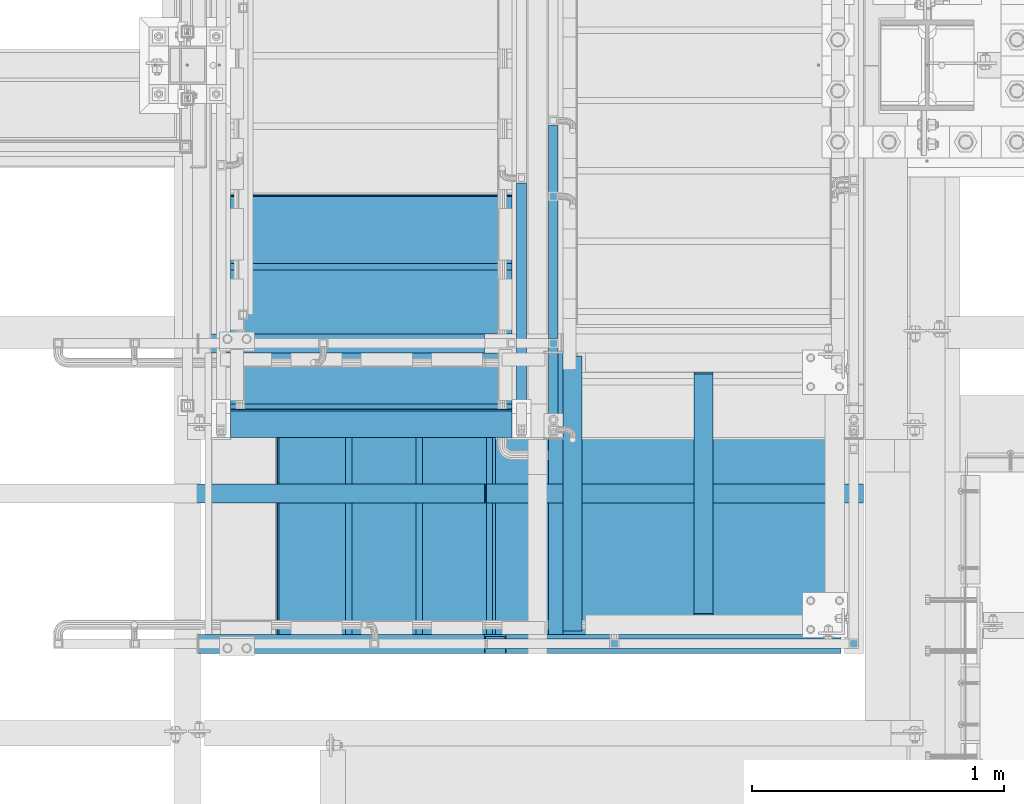
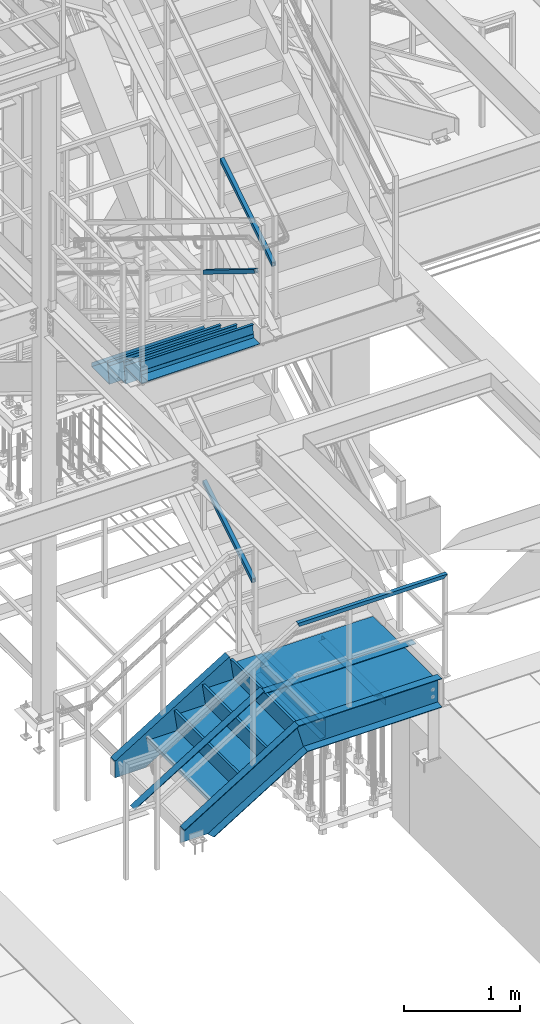
# One storey, part 1761 of 3843: 13 beams, 7 members, 8 elements without a shape of their own.
"""IFC2X3 building model written with IfcOpenShell, lengths in millimetres."""

from ifc_helpers import new_model, si_unit, frame, origin_with_axes, place, context, subcontext, project, spatial, faceted_brep, material, type_object, element, aggregate, save


model = new_model("IFC2X3")

# Units and contexts
model_context = context("Model", 3, precision=1e-05, world=origin_with_axes())
body_context = subcontext(model_context, "Body", "Model", "MODEL_VIEW")
ifc_project = project(units=[si_unit("LENGTHUNIT", "METRE", prefix="MILLI"), si_unit("AREAUNIT", "SQUARE_METRE"), si_unit("VOLUMEUNIT", "CUBIC_METRE"), si_unit("MASSUNIT", "GRAM", prefix="KILO"), si_unit("TIMEUNIT", "SECOND"), si_unit("PLANEANGLEUNIT", "RADIAN"), si_unit("SOLIDANGLEUNIT", "STERADIAN"), si_unit("THERMODYNAMICTEMPERATUREUNIT", "DEGREE_CELSIUS"), si_unit("LUMINOUSINTENSITYUNIT", "LUMEN")], contexts=[model_context])

# Site, building, storey
site_placement = place(None, origin_with_axes())
site = spatial("IfcSite", under=ifc_project, at=site_placement, CompositionType="ELEMENT")
building_placement = place(site_placement, origin_with_axes())
building = spatial("IfcBuilding", under=site, at=building_placement, Name="Undefined", CompositionType="ELEMENT")
storey_placement = place(building_placement, origin_with_axes())
storey = spatial("IfcBuildingStorey", under=building, at=storey_placement, Name="Undefined", CompositionType="ELEMENT", Elevation=0.0)

# Assembly, beam
assembly_1_placement = place(storey_placement, origin_with_axes())
assembly_1 = element("IfcElementAssembly", 1, at=assembly_1_placement, inside=storey, Name="RAIL", AssemblyPlace="NOTDEFINED", PredefinedType="RIGID_FRAME")
ifc_material_1 = material()
beam_type_1 = type_object("IfcBeamType", Name="HSS1-1/2X1-1/2X1/4", PredefinedType="NOTDEFINED")
beam_1_placement = place(assembly_1_placement, frame((54057.5499999943, 18008.6000001452, 32406.4923070972), z_axis=(0.0, 0.0, -1.0), x_axis=(1.0, 0.0, 0.0)))
beam_1 = element("IfcBeam", 2, at=beam_1_placement, type_object=beam_type_1, material=ifc_material_1, Name="RAIL", ObjectType="HSS1-1/2X1-1/2X1/4", context=body_context, shape_type="Brep", body=[
    faceted_brep([(1562.10000076667, -19.0499992350015, 19.0499992350015), (1562.10000076667, 19.0499992350015, 19.0499992350015), (126.041952911473, 19.0499992350015, 19.0499992350015), (126.041952911473, -19.0499992350015, 19.0499992350015), (1600.19999923668, -19.0499992350015, -19.0499992350015), (115.258045902359, -19.0499992350015, -19.0499992350015), (1600.19999923668, 19.0499992350015, -19.0499992350015), (115.258045902359, 19.0499992350015, -19.0499992350015), (1568.45000067168, -12.6999993300014, 12.6999993300014), (1568.45000067168, 12.6999993300014, 12.6999993300014), (1593.84999933167, 12.6999993300014, -12.6999993300014), (1593.84999933167, -12.6999993300014, -12.6999993300014), (124.24463503134, -12.6999993300014, 12.6999993300014), (124.24463503134, 12.6999993300014, 12.6999993300014), (117.0553637825, 12.6999993300014, -12.6999993300014), (117.0553637825, -12.6999993300014, -12.6999993300014)], [[[0, 1, 2, 3]], [[4, 0, 3, 5]], [[6, 4, 5, 7]], [[1, 6, 7, 2]], [[0, 4, 6, 1], [8, 9, 10, 11]], [[9, 8, 12, 13]], [[10, 9, 13, 14]], [[11, 10, 14, 15]], [[8, 11, 15, 12]], [[7, 5, 3, 2], [14, 13, 12, 15]]]),
])
aggregate(assembly_1, [beam_1])

# Assembly, member
assembly_2_placement = place(storey_placement, origin_with_axes())
assembly_2 = element("IfcElementAssembly", 3, at=assembly_2_placement, inside=storey, Name="RAIL", AssemblyPlace="NOTDEFINED", PredefinedType="RIGID_FRAME")
member_type_1 = type_object("IfcMemberType", Name="HSS1-1/2X1-1/2X1/4", PredefinedType="NOTDEFINED")
member_1_placement = place(assembly_2_placement, frame((54444.8999999993, 18859.5000000038, 35547.2230284888), z_axis=(0.0, -0.529536736899111, 0.848287005838379), x_axis=(0.0, 0.848287005838377, 0.529536736899114)))
member_1 = element("IfcMember", 4, at=member_1_placement, type_object=member_type_1, material=ifc_material_1, Name="RAIL", ObjectType="HSS1-1/2X1-1/2X1/4", context=body_context, shape_type="Brep", body=[
    faceted_brep([(1082.34320237271, -19.0499992350015, 19.0499992316145), (1058.55956696786, -19.0499992350015, -19.0499992382502), (1058.55956696786, 19.0499992350015, -19.0499992382502), (1082.34320237271, 19.0499992350015, 19.0499992316145), (1078.3792630387, -12.6999993299978, 12.6999993266436), (1078.3792630387, 12.6999993299978, 12.6999993266436), (1062.52350630188, 12.6999993299978, -12.6999993332684), (1062.52350630188, -12.6999993299978, -12.6999993332684), (34.3488397583606, 19.0499992350015, 19.0499992348923), (34.3488397583606, -19.0499999999956, 19.0499992348923), (10.5652043534537, -19.0499992350015, -19.0499992349432), (10.5652043534537, 19.0499992350015, -19.0499992349432), (30.3849004243275, -12.6999993300014, 12.6999993299178), (14.5291436874832, -12.6999993300014, -12.6999993299687), (14.5291436874832, 12.6999993300014, -12.6999993299687), (30.3849004243275, 12.6999993300014, 12.6999993299178)], [[[0, 1, 2, 3], [4, 5, 6, 7]], [[0, 3, 8, 9]], [[2, 1, 10, 11]], [[1, 0, 9, 10]], [[3, 2, 11, 8]], [[9, 8, 11, 10], [12, 13, 14, 15]], [[4, 7, 13, 12]], [[7, 6, 14, 13]], [[6, 5, 15, 14]], [[5, 4, 12, 15]]]),
])
aggregate(assembly_2, [member_1])

assembly_3_placement = place(storey_placement, origin_with_axes())
assembly_3 = element("IfcElementAssembly", 5, at=assembly_3_placement, inside=storey, Name="RAIL", AssemblyPlace="NOTDEFINED", PredefinedType="RIGID_FRAME")
member_2_placement = place(assembly_3_placement, frame((54317.8999999992, 19858.5666666609, 34931.5128165866), z_axis=(0.0, 0.5240974250506, 0.851658317082227), x_axis=(0.0, -0.851658317082228, 0.524097425050598)))
member_2 = element("IfcMember", 6, at=member_2_placement, type_object=member_type_1, material=ifc_material_1, Name="RAIL", ObjectType="HSS1-1/2X1-1/2X1/4", context=body_context, shape_type="Brep", body=[
    faceted_brep([(14.5527402998268, 12.6999993300014, -12.6999993299833), (14.5527402998268, -12.6999993300014, -12.6999993299833), (1050.19260690852, -12.6999993299978, -12.6999993321297), (1050.19260690852, 12.6999993299978, -12.6999993321297), (30.1835087105574, -12.6999993300014, 12.6999993299978), (1057.38187815647, -12.6999993299978, 12.699999327946), (30.1835087105574, 12.6999993300014, 12.6999993299978), (1057.38187815647, 12.6999993299978, 12.699999327946), (10.6450480494532, 19.0499992350015, -19.0499992349796), (34.091200960931, 19.0499992350015, 19.0499992349942), (1059.17919603638, 19.0499992350015, 19.0499992329715), (1048.39528902861, 19.0499992350015, -19.0499992371551), (34.091200960931, -19.0499992350015, 19.0499992349942), (1059.17919603638, -19.0499992350015, 19.0499992329715), (10.6450480494532, -19.0499992350015, -19.0499992349796), (1048.39528902861, -19.0499992350015, -19.0499992371551)], [[[0, 1, 2, 3]], [[1, 4, 5, 2]], [[4, 6, 7, 5]], [[6, 0, 3, 7]], [[8, 9, 10, 11]], [[9, 12, 13, 10]], [[12, 14, 15, 13]], [[14, 8, 11, 15]], [[13, 15, 11, 10], [5, 7, 3, 2]], [[14, 12, 9, 8], [6, 4, 1, 0]]]),
])
aggregate(assembly_3, [member_2])

assembly_4_placement = place(storey_placement, origin_with_axes())
assembly_4 = element("IfcElementAssembly", 7, at=assembly_4_placement, inside=storey, Name="RAIL", AssemblyPlace="NOTDEFINED", PredefinedType="RIGID_FRAME")
member_3_placement = place(assembly_4_placement, frame((54444.9000000015, 19202.3999999958, 32021.5846158689), z_axis=(0.0, -0.524097425050603, 0.851658317082225), x_axis=(0.0, 0.851658317082228, 0.524097425050598)))
member_3 = element("IfcMember", 8, at=member_3_placement, type_object=member_type_1, material=ifc_material_1, Name="RAIL", ObjectType="HSS1-1/2X1-1/2X1/4", context=body_context, shape_type="Brep", body=[
    faceted_brep([(1028.23010755839, -19.0499992350015, 19.0499992361583), (1004.7839546916, -19.0499992350015, -19.0499992338882), (1004.7839546916, 19.0499992350015, -19.0499992338882), (1028.23010755839, 19.0499992350015, 19.0499992361583), (1024.32241531547, -12.6999993299978, 12.6999993311474), (1024.32241531547, 12.6999993299978, 12.6999993311474), (1008.69164693452, 12.6999993299978, -12.6999993288846), (1008.69164693452, -12.6999993299978, -12.6999993288846), (34.091200960931, 19.0499992350015, 19.0499992349942), (34.091200960931, -19.0499992350015, 19.0499992349942), (10.6450480494532, -19.0499992350015, -19.0499992349796), (10.6450480494532, 19.0499992350015, -19.0499992349796), (30.1835087105574, 12.6999993300014, 12.6999993299978), (30.1835087105574, -12.6999993300014, 12.6999993299978), (14.5527402998268, -12.6999993300014, -12.6999993299833), (14.5527402998268, 12.6999993300014, -12.6999993299833)], [[[0, 1, 2, 3], [4, 5, 6, 7]], [[0, 3, 8, 9]], [[2, 1, 10, 11]], [[1, 0, 9, 10]], [[3, 2, 11, 8]], [[10, 9, 8, 11], [12, 13, 14, 15]], [[4, 7, 14, 13]], [[7, 6, 15, 14]], [[6, 5, 12, 15]], [[5, 4, 13, 12]]]),
])
aggregate(assembly_4, [member_3])

# Assembly, beams
assembly_5_placement = place(storey_placement, origin_with_axes())
assembly_5 = element("IfcElementAssembly", 9, at=assembly_5_placement, inside=storey, Name="STAIR", AssemblyPlace="NOTDEFINED", PredefinedType="RIGID_FRAME")
ifc_material_2 = material(Name="STEEL/ASTM A1011")
beam_type_2 = type_object("IfcBeamType", PredefinedType="NOTDEFINED")
beam_2_placement = place(assembly_5_placement, frame((53721.0000001991, 18935.6999999638, 34948.8124968837), z_axis=(-1.0, 0.0, 0.0), x_axis=(0.0, 1.0, 0.0)))
beam_2 = element("IfcBeam", 10, at=beam_2_placement, type_object=beam_type_2, material=ifc_material_2, Name="TREAD", context=body_context, shape_type="Brep", body=[
    faceted_brep([(0.0, -1.58750000000146, -558.799999999999), (0.0, -1.58750000000146, 558.799999999999), (0.0, 1.58750000000146, 558.799999999999), (0.0, 1.58750000000146, -558.799999999999), (21.7215083258779, 1.58750000000146, 558.799999999999), (21.7215083258779, 1.58750000000146, -558.799999999999), (25.3999999999942, -1.58750000000146, -558.799999999999), (25.3999999999942, -1.58750000000146, 558.799999999999), (-11.1830371286633, 224.325961538467, 558.799999999999), (-11.1830371286633, 224.325961538467, -558.799999999999), (-7.50454545454704, 221.150961538464, -558.799999999999), (-7.50454545454704, 221.150961538464, 558.799999999999), (293.616962871325, 224.325961538467, 558.799999999999), (293.616962871325, 224.325961538467, -558.799999999999), (290.876539379024, 221.150961538464, -558.799999999999), (290.876539379024, 221.150961538464, 558.799999999999), (299.585432747743, 183.924011605752, 558.799999999999), (299.585432747743, 183.924011605752, -558.799999999999), (296.444520385252, 183.460013188564, 558.799999999999), (296.444520385252, 183.460013188564, -558.799999999999)], [[[0, 1, 2, 3]], [[3, 2, 4, 5]], [[1, 0, 6, 7]], [[5, 4, 8, 9]], [[7, 6, 10, 11]], [[9, 8, 12, 13]], [[11, 10, 14, 15]], [[13, 12, 16, 17]], [[12, 8, 4, 2, 1, 7, 11, 15, 18, 16]], [[15, 14, 19, 18]], [[14, 10, 6, 0, 3, 5, 9, 13, 17, 19]], [[18, 19, 17, 16]]]),
])
beam_3_placement = place(assembly_5_placement, frame((53721.0000001966, 19215.0999999668, 34776.8740354687), z_axis=(-1.0, 0.0, 0.0), x_axis=(0.0, 1.0, 0.0)))
beam_3 = element("IfcBeam", 11, at=beam_3_placement, type_object=beam_type_2, material=ifc_material_2, Name="TREAD", context=body_context, shape_type="Brep", body=[
    faceted_brep([(0.0, -1.58750000000146, -558.799999999999), (0.0, -1.58750000000146, 558.799999999999), (0.0, 1.58750000000146, 558.799999999999), (0.0, 1.58750000000146, -558.799999999999), (21.7215083258779, 1.58750000000146, 558.799999999999), (21.7215083258779, 1.58750000000146, -558.799999999999), (25.3999999999942, -1.58750000000146, -558.799999999999), (25.3999999999942, -1.58750000000146, 558.799999999999), (-11.1830371286633, 224.325961538467, 558.799999999999), (-11.1830371286633, 224.325961538467, -558.799999999999), (-7.50454545454704, 221.150961538464, -558.799999999999), (-7.50454545454704, 221.150961538464, 558.799999999999), (293.616962871325, 224.325961538467, 558.799999999999), (293.616962871325, 224.325961538467, -558.799999999999), (290.876539379024, 221.150961538464, -558.799999999999), (290.876539379024, 221.150961538464, 558.799999999999), (299.585432747743, 183.924011605752, 558.799999999999), (299.585432747743, 183.924011605752, -558.799999999999), (296.444520385252, 183.460013188564, 558.799999999999), (296.444520385252, 183.460013188564, -558.799999999999)], [[[0, 1, 2, 3]], [[3, 2, 4, 5]], [[1, 0, 6, 7]], [[5, 4, 8, 9]], [[7, 6, 10, 11]], [[9, 8, 12, 13]], [[11, 10, 14, 15]], [[13, 12, 16, 17]], [[12, 8, 4, 2, 1, 7, 11, 15, 18, 16]], [[15, 14, 19, 18]], [[14, 10, 6, 0, 3, 5, 9, 13, 17, 19]], [[18, 19, 17, 16]]]),
])
beam_4_placement = place(assembly_5_placement, frame((53721.0000001941, 19494.4999999697, 34604.9355740537), z_axis=(-1.0, 0.0, 0.0), x_axis=(0.0, 1.0, 0.0)))
beam_4 = element("IfcBeam", 12, at=beam_4_placement, type_object=beam_type_2, material=ifc_material_2, Name="TREAD", context=body_context, shape_type="Brep", body=[
    faceted_brep([(0.0, -1.58750000000146, -558.799999999999), (0.0, -1.58750000000146, 558.799999999999), (0.0, 1.58750000000146, 558.799999999999), (0.0, 1.58750000000146, -558.799999999999), (21.7215083258779, 1.58750000000146, 558.799999999999), (21.7215083258779, 1.58750000000146, -558.799999999999), (25.3999999999942, -1.58750000000146, -558.799999999999), (25.3999999999942, -1.58750000000146, 558.799999999999), (-11.1830371286633, 224.325961538467, 558.799999999999), (-11.1830371286633, 224.325961538467, -558.799999999999), (-7.50454545454704, 221.150961538464, -558.799999999999), (-7.50454545454704, 221.150961538464, 558.799999999999), (293.616962871325, 224.325961538467, 558.799999999999), (293.616962871325, 224.325961538467, -558.799999999999), (290.876539379024, 221.150961538464, -558.799999999999), (290.876539379024, 221.150961538464, 558.799999999999), (299.585432747743, 183.924011605752, 558.799999999999), (299.585432747743, 183.924011605752, -558.799999999999), (296.444520385252, 183.460013188564, 558.799999999999), (296.444520385252, 183.460013188564, -558.799999999999)], [[[0, 1, 2, 3]], [[3, 2, 4, 5]], [[1, 0, 6, 7]], [[5, 4, 8, 9]], [[7, 6, 10, 11]], [[9, 8, 12, 13]], [[11, 10, 14, 15]], [[13, 12, 16, 17]], [[12, 8, 4, 2, 1, 7, 11, 15, 18, 16]], [[15, 14, 19, 18]], [[14, 10, 6, 0, 3, 5, 9, 13, 17, 19]], [[18, 19, 17, 16]]]),
])

# Assembly, beams, members
assembly_6_placement = place(storey_placement, origin_with_axes())
assembly_6 = element("IfcElementAssembly", 13, at=assembly_6_placement, inside=storey, Name="STAIR", AssemblyPlace="NOTDEFINED", PredefinedType="RIGID_FRAME")
beam_5_placement = place(assembly_6_placement, frame((54203.5999999953, 18605.5000001452, 31338.104807095), z_axis=(0.0, -1.0, 0.0), x_axis=(-1.0, 0.0, 0.0)))
beam_5 = element("IfcBeam", 14, at=beam_5_placement, type_object=beam_type_2, material=ifc_material_2, Name="TREAD", context=body_context, shape_type="Brep", body=[
    faceted_brep([(0.0, -1.58750000000146, -558.799999999999), (0.0, -1.58750000000146, 558.799999999999), (0.0, 1.58750000000146, 558.799999999999), (0.0, 1.58750000000146, -558.799999999999), (21.7215083258779, 1.58750000000146, 558.799999999999), (21.7215083258779, 1.58750000000146, -558.799999999999), (25.3999999999942, -1.58750000000146, -558.799999999999), (25.3999999999942, -1.58750000000146, 558.799999999999), (-11.1830371286633, 224.325961538467, 558.799999999999), (-11.1830371286633, 224.325961538467, -558.799999999999), (-7.50454545454704, 221.150961538464, -558.799999999999), (-7.50454545454704, 221.150961538464, 558.799999999999), (293.616962871325, 224.325961538467, 558.799999999999), (293.616962871325, 224.325961538467, -558.799999999999), (290.876539379024, 221.150961538464, -558.799999999999), (290.876539379024, 221.150961538464, 558.799999999999), (299.585432747743, 183.924011605752, 558.799999999999), (299.585432747743, 183.924011605752, -558.799999999999), (296.444520385252, 183.460013188564, 558.799999999999), (296.444520385252, 183.460013188564, -558.799999999999)], [[[0, 1, 2, 3]], [[3, 2, 4, 5]], [[1, 0, 6, 7]], [[5, 4, 8, 9]], [[7, 6, 10, 11]], [[9, 8, 12, 13]], [[11, 10, 14, 15]], [[13, 12, 16, 17]], [[12, 8, 4, 2, 1, 7, 11, 15, 18, 16]], [[15, 14, 19, 18]], [[14, 10, 6, 0, 3, 5, 9, 13, 17, 19]], [[18, 19, 17, 16]]]),
])
beam_6_placement = place(assembly_6_placement, frame((53924.199999994, 18605.5000001452, 31166.1663456759), z_axis=(0.0, -1.0, 0.0), x_axis=(-1.0, 0.0, 0.0)))
beam_6 = element("IfcBeam", 15, at=beam_6_placement, type_object=beam_type_2, material=ifc_material_2, Name="TREAD", context=body_context, shape_type="Brep", body=[
    faceted_brep([(0.0, -1.58750000000146, -558.799999999999), (0.0, -1.58750000000146, 558.799999999999), (0.0, 1.58750000000146, 558.799999999999), (0.0, 1.58750000000146, -558.799999999999), (21.7215083258779, 1.58750000000146, 558.799999999999), (21.7215083258779, 1.58750000000146, -558.799999999999), (25.3999999999942, -1.58750000000146, -558.799999999999), (25.3999999999942, -1.58750000000146, 558.799999999999), (-11.1830371286633, 224.325961538467, 558.799999999999), (-11.1830371286633, 224.325961538467, -558.799999999999), (-7.50454545454704, 221.150961538464, -558.799999999999), (-7.50454545454704, 221.150961538464, 558.799999999999), (293.616962871325, 224.325961538467, 558.799999999999), (293.616962871325, 224.325961538467, -558.799999999999), (290.876539379024, 221.150961538464, -558.799999999999), (290.876539379024, 221.150961538464, 558.799999999999), (299.585432747743, 183.924011605752, 558.799999999999), (299.585432747743, 183.924011605752, -558.799999999999), (296.444520385252, 183.460013188564, 558.799999999999), (296.444520385252, 183.460013188564, -558.799999999999)], [[[0, 1, 2, 3]], [[3, 2, 4, 5]], [[1, 0, 6, 7]], [[5, 4, 8, 9]], [[7, 6, 10, 11]], [[9, 8, 12, 13]], [[11, 10, 14, 15]], [[13, 12, 16, 17]], [[12, 8, 4, 2, 1, 7, 11, 15, 18, 16]], [[15, 14, 19, 18]], [[14, 10, 6, 0, 3, 5, 9, 13, 17, 19]], [[18, 19, 17, 16]]]),
])
beam_7_placement = place(assembly_6_placement, frame((53644.7999999928, 18605.5000001452, 30994.2278842569), z_axis=(0.0, -1.0, 0.0), x_axis=(-1.0, 0.0, 0.0)))
beam_7 = element("IfcBeam", 16, at=beam_7_placement, type_object=beam_type_2, material=ifc_material_2, Name="TREAD", context=body_context, shape_type="Brep", body=[
    faceted_brep([(0.0, -1.58750000000146, -558.799999999999), (0.0, -1.58750000000146, 558.799999999999), (0.0, 1.58750000000146, 558.799999999999), (0.0, 1.58750000000146, -558.799999999999), (21.7215083258779, 1.58750000000146, 558.799999999999), (21.7215083258779, 1.58750000000146, -558.799999999999), (25.3999999999942, -1.58750000000146, -558.799999999999), (25.3999999999942, -1.58750000000146, 558.799999999999), (-11.1830371286633, 224.325961538467, 558.799999999999), (-11.1830371286633, 224.325961538467, -558.799999999999), (-7.50454545454704, 221.150961538464, -558.799999999999), (-7.50454545454704, 221.150961538464, 558.799999999999), (293.616962871325, 224.325961538467, 558.799999999999), (293.616962871325, 224.325961538467, -558.799999999999), (290.876539379024, 221.150961538464, -558.799999999999), (290.876539379024, 221.150961538464, 558.799999999999), (299.585432747743, 183.924011605752, 558.799999999999), (299.585432747743, 183.924011605752, -558.799999999999), (296.444520385252, 183.460013188564, 558.799999999999), (296.444520385252, 183.460013188564, -558.799999999999)], [[[0, 1, 2, 3]], [[3, 2, 4, 5]], [[1, 0, 6, 7]], [[5, 4, 8, 9]], [[7, 6, 10, 11]], [[9, 8, 12, 13]], [[11, 10, 14, 15]], [[13, 12, 16, 17]], [[12, 8, 4, 2, 1, 7, 11, 15, 18, 16]], [[15, 14, 19, 18]], [[14, 10, 6, 0, 3, 5, 9, 13, 17, 19]], [[18, 19, 17, 16]]]),
])
ifc_material_3 = material(Name="STEEL/A36")
beam_type_3 = type_object("IfcBeamType", Name="C12X20.7", PredefinedType="NOTDEFINED")
beam_8_placement = place(assembly_6_placement, frame((54171.0107283524, 18008.600000064, 31212.6923070751), z_axis=(0.0, 0.0, 1.0), x_axis=(1.0, 0.0, 0.0)))
beam_8 = element("IfcBeam", 17, at=beam_8_placement, type_object=beam_type_3, material=ifc_material_3, Name="STAIR", ObjectType="C12X20.7", context=body_context, shape_type="Brep", body=[
    faceted_brep([(86.2712597135396, -38.0999999999985, -152.39999999988), (84.4732228755893, -38.0999999999985, -146.047459999883), (81.2543163632508, 30.1624999999985, -134.674927499889), (5.01694334564672, 30.1624999999985, 134.674927499867), (1.79803683332284, -38.0999999999985, 146.047459999862), (0.0, -38.0999999999985, 152.400000000001), (0.0, 38.0999999999985, 152.400000000001), (86.2712597135396, 38.0999999999985, -152.39999999988), (1416.88927164768, -38.0999999999985, 152.400000000001), (1416.88927164768, 38.0999999999985, 152.400000000001), (1416.88927164768, 38.0999999999985, -152.400000000001), (1416.88927164768, -38.0999999999985, -152.400000000001), (1416.88927164768, -38.0999999999985, -146.047460000002), (1416.88927164768, 30.1624999999985, -134.6749275), (1416.88927164768, 30.1624999999985, 134.6749275), (1416.88927164768, -38.0999999999985, 146.047460000002)], [[[0, 1, 2, 3, 4, 5, 6, 7]], [[6, 5, 8, 9]], [[7, 6, 9, 10]], [[0, 7, 10, 11]], [[1, 0, 11, 12]], [[2, 1, 12, 13]], [[3, 2, 13, 14]], [[4, 3, 14, 15]], [[5, 4, 15, 8]], [[14, 13, 12, 11, 10, 9, 8, 15]]]),
])
member_type_2 = type_object("IfcMemberType", Name="C12X20.7", PredefinedType="NOTDEFINED")
member_4_placement = place(assembly_6_placement, frame((54250.8831759882, 19202.4000000608, 31235.2995795919), z_axis=(-0.524097425775922, 0.0, 0.851658316635875), x_axis=(-0.851658316635875, 0.0, -0.524097425775922)))
member_4 = element("IfcMember", 18, at=member_4_placement, type_object=member_type_2, material=ifc_material_3, Name="STAIR", ObjectType="C12X20.7", context=body_context, shape_type="Brep", body=[
    faceted_brep([(86.2712597135396, -38.0999999999985, -152.39999999988), (84.4732228755893, -38.0999999999985, -146.047459999883), (81.2543163632508, 30.1624999999985, -134.674927499889), (5.01694334564672, 30.1624999999985, 134.674927499867), (1.79803683332284, -38.0999999999985, 146.047459999862), (0.0, -38.0999999999985, 152.400000000001), (0.0, 38.0999999999985, 152.400000000001), (86.2712597135396, 38.0999999999985, -152.39999999988), (1169.26132963897, 38.0999999999985, -152.399999998874), (1169.26132963897, -38.0999999999985, -152.399999998874), (1179.58420715575, -38.0999999999985, -146.047459998881), (1198.0645724983, 30.1624999999985, -134.67492749888), (1424.54121528564, 30.1624999999985, 4.69531398983236), (1344.55376094554, 30.1624999999985, 134.674927500895), (1337.5552794183, -38.0999999999985, 146.047460000875), (1333.64602403997, -38.0999999999985, 152.400000000864), (1333.64602403997, 38.0999999999985, 152.400000000864), (1424.54121528564, 38.0999999999985, 4.69531398983236)], [[[0, 1, 2, 3, 4, 5, 6, 7]], [[0, 7, 8, 9]], [[1, 0, 9, 10]], [[2, 1, 10, 11]], [[3, 2, 11, 12, 13]], [[4, 3, 13, 14]], [[5, 4, 14, 15]], [[6, 5, 15, 16]], [[8, 7, 6, 16, 17]], [[11, 10, 9, 8, 17, 12]], [[16, 15, 14, 13, 12, 17]]]),
])
member_5_placement = place(assembly_6_placement, frame((52936.4331760563, 18008.6000000644, 30426.4072725079), z_axis=(-0.524097425775922, 0.0, 0.851658316635875), x_axis=(0.851658316635872, 0.0, 0.524097425775926)))
member_5 = element("IfcMember", 19, at=member_5_placement, type_object=member_type_2, material=ifc_material_3, Name="STAIR", ObjectType="C12X20.7", context=body_context, shape_type="Brep", body=[
    faceted_brep([(345.336078011489, 30.1624999999985, -134.67492749968), (363.81644331853, -38.0999999999985, -146.047459999656), (1458.9274283898, -38.0999999999985, -146.047460000975), (1462.14633489506, 30.1624999999985, -134.674927500992), (374.139320815477, -38.0999999999985, -152.399999999641), (1457.12939155579, -38.0999999999985, -152.400000000967), (374.139320815477, 38.0999999999985, -152.399999999641), (1457.12939155579, 38.0999999999985, -152.400000000967), (1543.40065108441, -38.0999999999985, 152.399999998581), (1541.60261425041, -38.0999999999985, 146.047459998592), (1538.38370774514, 30.1624999999985, 134.674927498605), (1543.40065108441, 38.0999999999985, 152.399999998581), (209.754625973874, -38.0999999999985, 152.399999999951), (205.845370588111, -38.0999999999985, 146.047459999954), (198.846889047592, 30.1624999999985, 134.674927499964), (118.859434858809, 30.1624999999985, 4.69531448134148), (118.859434858809, 38.0999999999985, 4.69531448134148), (209.754625973874, 38.0999999999985, 152.399999999951)], [[[0, 1, 2, 3]], [[1, 4, 5, 2]], [[4, 6, 7, 5]], [[8, 9, 10, 3, 2, 5, 7, 11]], [[9, 8, 12, 13]], [[10, 9, 13, 14]], [[0, 3, 10, 14, 15]], [[6, 4, 1, 0, 15, 16]], [[11, 7, 6, 16, 17]], [[8, 11, 17, 12]], [[16, 15, 14, 13, 12, 17]]]),
])
beam_type_4 = type_object("IfcBeamType", Name="L3X3X1/4", PredefinedType="NOTDEFINED")
beam_9_placement = place(assembly_6_placement, frame((55041.7999999999, 19164.3000000617, 31250.7923071027), z_axis=(-1.0, 0.0, 0.0), x_axis=(0.0, -1.0, 0.0)))
beam_9 = element("IfcBeam", 20, at=beam_9_placement, type_object=beam_type_4, material=ifc_material_3, Name="ANGLE", ObjectType="L3X3X1/4", context=body_context, shape_type="Brep", body=[
    faceted_brep([(1041.40000012286, 31.75, 38.0999999999985), (1041.40000012286, 31.75, -31.75), (1041.40000012286, 31.7499999942156, -38.0999999999985), (1035.05000012226, 38.0999999999985, -38.0999999999985), (1035.05000012226, 38.0999999999985, 38.0999999999985), (1098.55000012286, 31.75, -31.75), (1098.55000012286, 31.7499999942156, -38.0999999999985), (1111.25000012285, 19.0499999942185, -31.75), (1111.25000012285, 19.0499999942185, -38.0999999999985), (1111.25000012344, -38.1000000057757, -31.75), (1111.25000012344, -38.0999999999985, -38.0999999999985), (82.5500000005923, 38.0999999999985, 38.0999999999985), (82.5499948264696, 38.0999999999458, -38.0999999999985), (76.1999999999971, 31.7499999999927, -38.0999999999985), (76.1999999999971, 31.75, -31.75), (76.1999999999971, 31.75, 38.0999999999985), (19.0499999999956, 31.7499999999927, -38.0999999999985), (19.0500000000029, 31.75, -31.75), (6.34999999999854, 19.0499999999956, -38.0999999999985), (6.34999999999854, 19.0499999999956, -31.75), (6.34999999941647, -38.0999999999985, -31.75), (6.34999999941647, -38.0999999999985, -38.0999999999985)], [[[0, 1, 2, 3, 4]], [[5, 6, 2, 1]], [[7, 8, 6, 5]], [[9, 10, 8, 7]], [[11, 12, 13, 14, 15]], [[14, 13, 16, 17]], [[17, 16, 18, 19]], [[20, 19, 18, 21]], [[5, 1, 14, 17, 19, 20, 9, 7]], [[15, 14, 1, 0]], [[11, 15, 0, 4]], [[12, 11, 4, 3]], [[21, 18, 16, 13, 12, 3, 2, 6, 8, 10]], [[20, 21, 10, 9]]]),
])
beam_10_placement = place(assembly_6_placement, frame((54521.0999999999, 18059.4000001457, 31250.792307111), z_axis=(1.0, 0.0, 0.0), x_axis=(0.0, 1.0, 0.0)))
beam_10 = element("IfcBeam", 21, at=beam_10_placement, type_object=beam_type_4, material=ifc_material_3, Name="ANGLE", ObjectType="L3X3X1/4", context=body_context, shape_type="Brep", body=[
    faceted_brep([(0.0, 25.3999999519947, -31.75), (0.0, 25.4000000000015, -38.0999999999985), (88.9000015258935, 25.399999952002, -38.0999999999985), (88.9000015258935, 25.399999952002, -31.75), (88.9000015261336, -38.1000000000131, -31.75), (88.9000015261336, -38.0999999999985, -38.0999999999985), (0.0, 38.0999999999985, -38.0999999999985), (0.0, 38.0999999999985, 38.0999999999985), (1092.20000022635, 38.0999999990308, 38.0999999999985), (1092.20000022635, 38.0999999990308, -38.0999999999985), (0.0, 31.75, 38.0999999999985), (1092.19999991878, 31.75, 38.0999999999985), (0.0, 31.75, -31.75), (1092.20000022113, 31.75, -31.75), (1092.19999991823, 25.3999999520238, -31.75), (1092.19999991849, 25.3999999520238, -38.0999999999985), (1003.29999839235, 25.3999999520238, -31.75), (1003.29999839235, 25.3999999520238, -38.0999999999985), (1003.29999998639, -38.0999999999985, -31.75), (1003.29999998639, -38.0999999999985, -38.0999999999985)], [[[0, 1, 2, 3]], [[4, 3, 2, 5]], [[6, 7, 8, 9]], [[7, 10, 11, 8]], [[10, 12, 13, 11]], [[9, 8, 11, 13, 14, 15]], [[14, 16, 17, 15]], [[18, 19, 17, 16]], [[19, 18, 4, 5]], [[1, 6, 9, 15, 17, 19, 5, 2]], [[12, 10, 7, 6, 1, 0]], [[18, 16, 14, 13, 12, 0, 3, 4]]]),
])

# Assembly, member
assembly_7_placement = place(storey_placement, origin_with_axes())
assembly_7 = element("IfcElementAssembly", 22, at=assembly_7_placement, inside=storey, Name="ref.", AssemblyPlace="NOTDEFINED", PredefinedType="RIGID_FRAME")
ifc_material_4 = material(Name="STEEL/Steel_Undefined")
member_type_3 = type_object("IfcMemberType", PredefinedType="NOTDEFINED")
member_6_placement = place(assembly_7_placement, frame((54178.1999999953, 18605.5000001452, 31336.5173070972), z_axis=(0.0, 1.0, 0.0), x_axis=(1.0, 0.0, 0.0)))
member_6 = element("IfcMember", 23, at=member_6_placement, type_object=member_type_3, material=ifc_material_4, Name="ref.", context=body_context, shape_type="Brep", body=[
    faceted_brep([(0.0, 3.17500000000291, -38.0999999999985), (0.0, 3.17500000000291, 38.0999999999985), (1498.60000000407, 3.17499999999927, 38.0999999999985), (1498.60000000407, 3.17499999999927, -38.0999999999985), (0.0, -3.17500000000291, 38.0999999999985), (1498.60000000407, -3.17499999999927, 38.0999999999985), (0.0, -3.17500000000291, -38.0999999999985), (1498.60000000407, -3.17499999999927, -38.0999999999985)], [[[0, 1, 2, 3]], [[1, 4, 5, 2]], [[4, 6, 7, 5]], [[6, 0, 3, 7]], [[5, 7, 3, 2]], [[6, 4, 1, 0]]]),
])
aggregate(assembly_7, [member_6])

assembly_8_placement = place(storey_placement, origin_with_axes())
assembly_8 = element("IfcElementAssembly", 24, at=assembly_8_placement, inside=storey, Name="ref.", AssemblyPlace="NOTDEFINED", PredefinedType="RIGID_FRAME")
member_7_placement = place(assembly_8_placement, frame((52885.4391605473, 18605.5000001452, 30570.2433226631), z_axis=(0.0, 1.0, 0.0), x_axis=(0.851658316635872, 0.0, 0.524097425775926)))
member_7 = element("IfcMember", 25, at=member_7_placement, type_object=member_type_3, material=ifc_material_4, Name="ref.", context=body_context, shape_type="Brep", body=[
    faceted_brep([(0.0, 3.17500000000291, -38.0999999999985), (0.0, 3.17500000000291, 38.0999999999985), (1511.44602394839, 3.17500000120344, 38.0999999999985), (1511.44602394839, 3.17500000120344, -38.0999999999985), (0.0, -3.17500000000291, 38.0999999999985), (1511.44602394839, -3.17499999879146, 38.0999999999985), (0.0, -3.17500000000291, -38.0999999999985), (1511.44602394839, -3.17499999879146, -38.0999999999985)], [[[0, 1, 2, 3]], [[1, 4, 5, 2]], [[4, 6, 7, 5]], [[6, 0, 3, 7]], [[5, 7, 3, 2]], [[6, 4, 1, 0]]]),
])
aggregate(assembly_8, [member_7])

# Beam
beam_type_5 = type_object("IfcBeamType", PredefinedType="NOTDEFINED")
beam_11_placement = place(assembly_6_placement, frame((55594.25, 18605.5000001452, 31290.4798070942), z_axis=(0.0, -1.0, 0.0), x_axis=(-1.0, 0.0, 0.0)))
beam_11 = element("IfcBeam", 26, at=beam_11_placement, type_object=beam_type_5, material=ifc_material_2, Name="PAN", context=body_context, shape_type="Brep", body=[
    faceted_brep([(0.0, -1.58750000000146, -558.799999999999), (0.0, -1.58750000000146, 558.799999999999), (0.0, 1.58750000000146, 558.799999999999), (0.0, 1.58750000000146, -558.799999999999), (1404.83040657854, 1.58749999806605, 558.799999999999), (1404.83040657854, 1.58749999806605, -558.799999999999), (1402.12653940557, -1.58750000193322, -558.799999999999), (1402.12653940557, -1.58750000193322, 558.799999999999), (1410.82899823045, -35.5978063572584, 558.799999999999), (1410.82899823045, -35.5978063572584, -558.799999999999), (1407.69452041527, -36.1034483513176, 558.799999999999), (1407.69452041527, -36.1034483513176, -558.799999999999)], [[[0, 1, 2, 3]], [[3, 2, 4, 5]], [[1, 0, 6, 7]], [[5, 4, 8, 9]], [[4, 2, 1, 7, 10, 8]], [[7, 6, 11, 10]], [[6, 0, 3, 5, 9, 11]], [[10, 11, 9, 8]]]),
])

beam_type_6 = type_object("IfcBeamType", Name="C8X11.5", PredefinedType="NOTDEFINED")
beam_12_placement = place(assembly_6_placement, frame((54454.4250000001, 19164.3000000585, 31187.292307063), z_axis=(0.0, 0.0, 1.0), x_axis=(0.0, -1.0, 0.0)))
beam_12 = element("IfcBeam", 27, at=beam_12_placement, type_object=beam_type_6, material=ifc_material_3, Name="STAIR", ObjectType="C8X11.5", context=body_context, shape_type="Brep", body=[
    faceted_brep([(0.0, 28.5750000000007, -101.599999999999), (0.0, 28.5750000000007, 101.599999999999), (1117.59999999544, 28.5750000000007, 101.599999999999), (1117.59999999544, 28.5750000000007, -101.599999999999), (0.0, -28.5750000000007, 101.599999999999), (1117.59999999544, -28.5750000000007, 101.599999999999), (0.0, -28.5750000000007, 96.8355949999968), (1117.59999999544, -28.5750000000007, 96.8355949999968), (0.0, 22.2249999999985, 88.3723150000005), (1117.59999999544, 22.2249999999985, 88.3723150000005), (0.0, 22.2249999999985, -88.3723150000005), (1117.59999999544, 22.2249999999985, -88.3723150000005), (0.0, -28.5750000000007, -96.8355949999968), (1117.59999999544, -28.5750000000007, -96.8355949999968), (0.0, -28.5750000000007, -101.599999999999), (1117.59999999544, -28.5750000000007, -101.599999999999)], [[[0, 1, 2, 3]], [[1, 4, 5, 2]], [[4, 6, 7, 5]], [[6, 8, 9, 7]], [[8, 10, 11, 9]], [[10, 12, 13, 11]], [[12, 14, 15, 13]], [[14, 0, 3, 15]], [[5, 7, 9, 11, 13, 15, 3, 2]], [[14, 12, 10, 8, 6, 4, 1, 0]]]),
])

aggregate(assembly_6, [beam_9, beam_10, beam_11, beam_12, beam_5, beam_6, beam_7, beam_8, member_4, member_5])

beam_type_7 = type_object("IfcBeamType", PredefinedType="NOTDEFINED")
beam_13_placement = place(assembly_5_placement, frame((53721.0000001971, 18827.75, 34812.2874968785), z_axis=(-1.0, 0.0, 0.0), x_axis=(0.0, 1.0, 0.0)))
beam_13 = element("IfcBeam", 28, at=beam_13_placement, type_object=beam_type_7, material=ifc_material_2, Name="TREAD", context=body_context, shape_type="Brep", body=[
    faceted_brep([(0.0, -1.58750000000146, -558.799999999999), (0.0, -1.58750000000146, 558.799999999999), (0.0, 1.58750000000146, 558.799999999999), (0.0, 1.58750000000146, -558.799999999999), (108.997451959196, 1.58749999468273, 558.800000000003), (108.997451959196, 1.58749999468273, -558.800000000003), (106.293584786166, -1.58750000518921, -558.800000000003), (106.293584786166, -1.58750000518921, 558.800000000003), (114.996043610565, -35.5978063607181, 558.800000000003), (114.996043610565, -35.5978063607181, -558.800000000003), (111.861565795381, -36.1034483547264, 558.800000000003), (111.861565795381, -36.1034483547264, -558.800000000003)], [[[0, 1, 2, 3]], [[3, 2, 4, 5]], [[1, 0, 6, 7]], [[5, 4, 8, 9]], [[4, 2, 1, 7, 10, 8]], [[7, 6, 11, 10]], [[6, 0, 3, 5, 9, 11]], [[10, 11, 9, 8]]]),
])

aggregate(assembly_5, [beam_2, beam_3, beam_13, beam_4])

save(model, "model.ifc")
